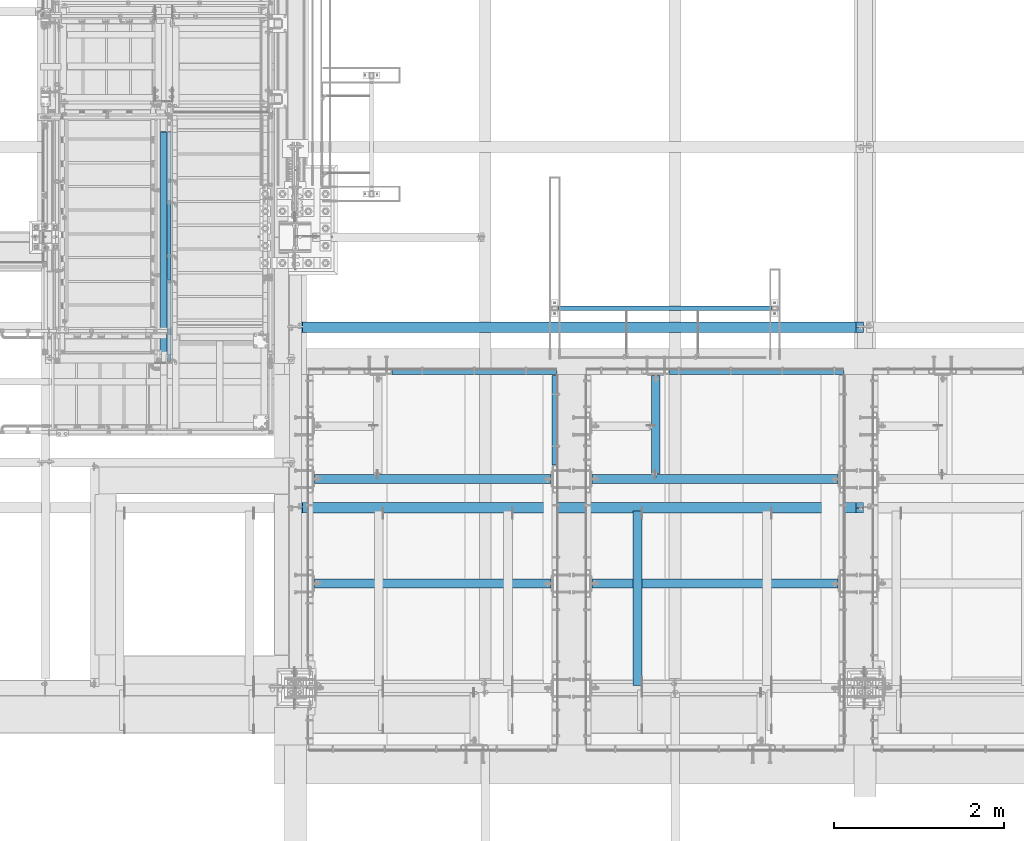
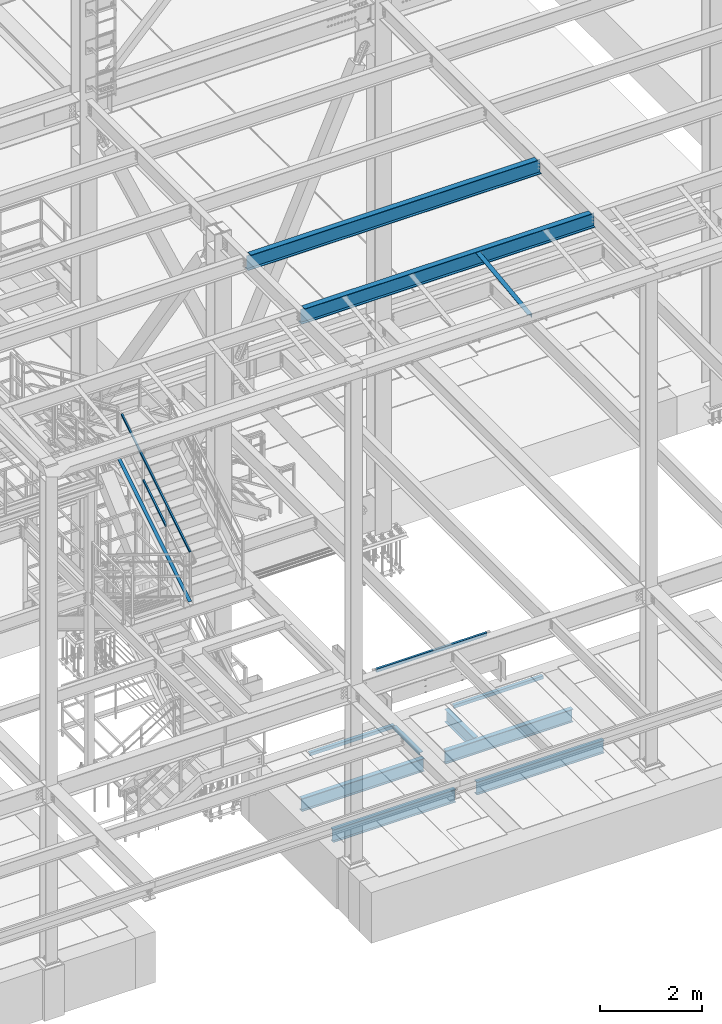
# One storey, part 1763 of 3843: 12 beams, 3 members, 14 elements without a shape of their own.
"""IFC2X3 building model written with IfcOpenShell, lengths in millimetres."""

from ifc_helpers import new_model, si_unit, frame, origin_with_axes, place, context, subcontext, project, spatial, faceted_brep, material, type_object, element, aggregate, save


model = new_model("IFC2X3")

# Units and contexts
model_context = context("Model", 3, precision=1e-05, world=origin_with_axes())
body_context = subcontext(model_context, "Body", "Model", "MODEL_VIEW")
ifc_project = project(units=[si_unit("LENGTHUNIT", "METRE", prefix="MILLI"), si_unit("AREAUNIT", "SQUARE_METRE"), si_unit("VOLUMEUNIT", "CUBIC_METRE"), si_unit("MASSUNIT", "GRAM", prefix="KILO"), si_unit("TIMEUNIT", "SECOND"), si_unit("PLANEANGLEUNIT", "RADIAN"), si_unit("SOLIDANGLEUNIT", "STERADIAN"), si_unit("THERMODYNAMICTEMPERATUREUNIT", "DEGREE_CELSIUS"), si_unit("LUMINOUSINTENSITYUNIT", "LUMEN")], contexts=[model_context])

# Site, building, storey
site_placement = place(None, origin_with_axes())
site = spatial("IfcSite", under=ifc_project, at=site_placement, CompositionType="ELEMENT")
building_placement = place(site_placement, origin_with_axes())
building = spatial("IfcBuilding", under=site, at=building_placement, Name="Undefined", CompositionType="ELEMENT")
storey_placement = place(building_placement, origin_with_axes())
storey = spatial("IfcBuildingStorey", under=building, at=storey_placement, Name="Undefined", CompositionType="ELEMENT", Elevation=0.0)

# Assembly, beam
assembly_1_placement = place(storey_placement, origin_with_axes())
assembly_1 = element("IfcElementAssembly", 1, at=assembly_1_placement, inside=storey, Name="FRAME", AssemblyPlace="NOTDEFINED", PredefinedType="RIGID_FRAME")
ifc_material_1 = material()
beam_type_1 = type_object("IfcBeamType", Name="HSS3X2X1/4", PredefinedType="NOTDEFINED")
beam_1_placement = place(assembly_1_placement, frame((58953.7793947567, 19468.65786883, 31267.4), z_axis=(0.0, 0.0, 1.0), x_axis=(1.0, 0.0, 0.0)))
beam_1 = element("IfcBeam", 2, at=beam_1_placement, type_object=beam_type_1, material=ifc_material_1, Name="FRAME", ObjectType="HSS3X2X1/4", context=body_context, shape_type="Brep", body=[
    faceted_brep([(67.8656249999985, 19.0499999999993, -31.75), (67.8656249999985, -19.0499999999993, -31.75), (2582.46562500002, -19.0499999999993, -31.75), (2582.46562500002, 19.0499999999993, -31.75), (67.8656249999985, -19.0499999999993, 31.75), (2582.46562500002, -19.0499999999993, 31.75), (67.8656249999985, 19.0499999999993, 31.75), (2582.46562500002, 19.0499999999993, 31.75), (67.8656249999985, 25.4000000000015, -38.0999999999985), (67.8656249999985, 25.4000000000015, 38.0999999999985), (2582.46562500002, 25.4000000000015, 38.0999999999985), (2582.46562500002, 25.4000000000015, -38.0999999999985), (67.8656249999985, -25.4000000000015, 38.0999999999985), (2582.46562500002, -25.4000000000015, 38.0999999999985), (67.8656249999985, -25.4000000000015, -38.0999999999985), (2582.46562500002, -25.4000000000015, -38.0999999999985)], [[[0, 1, 2, 3]], [[1, 4, 5, 2]], [[4, 6, 7, 5]], [[6, 0, 3, 7]], [[8, 9, 10, 11]], [[9, 12, 13, 10]], [[12, 14, 15, 13]], [[14, 8, 11, 15]], [[13, 15, 11, 10], [5, 7, 3, 2]], [[14, 12, 9, 8], [6, 4, 1, 0]]]),
])
aggregate(assembly_1, [beam_1])

# Assembly, members
assembly_2_placement = place(storey_placement, origin_with_axes())
assembly_2 = element("IfcElementAssembly", 3, at=assembly_2_placement, inside=storey, Name="RAIL", AssemblyPlace="NOTDEFINED", PredefinedType="RIGID_FRAME")
ifc_material_2 = material()
member_type_1 = type_object("IfcMemberType", Name="HSS1-1/2X1-1/2X1/4", PredefinedType="NOTDEFINED")
member_1_placement = place(assembly_2_placement, frame((54444.9000000038, 19786.6000000041, 36125.9581799186), z_axis=(0.0, -0.529536736899111, 0.848287005838379), x_axis=(0.0, 0.848287005838377, 0.529536736899114)))
member_1 = element("IfcMember", 4, at=member_1_placement, type_object=member_type_1, material=ifc_material_2, Name="RAIL", ObjectType="HSS1-1/2X1-1/2X1/4", context=body_context, shape_type="Brep", body=[
    faceted_brep([(34.3488397583606, -19.0499999999956, 19.0499992348923), (34.3488397583606, 19.0499992350015, 19.0499992348923), (10.5652043534537, 19.0499992350015, -19.0499992349432), (10.5652043534537, -19.0499992350015, -19.0499992349432), (30.3849004243275, -12.6999993300014, 12.6999993299178), (14.5291436874832, -12.6999993300014, -12.6999993299687), (14.5291436874832, 12.6999993300014, -12.6999993299687), (30.3849004243275, 12.6999993300014, 12.6999993299178), (1058.55956696786, 19.0499992350015, -19.0499992382502), (1058.55956696786, -19.0499992350015, -19.0499992382502), (1082.34320237271, -19.0499992350015, 19.0499992316145), (1082.34320237271, 19.0499992350015, 19.0499992316145), (1078.3792630387, -12.6999993299978, 12.6999993266436), (1078.3792630387, 12.6999993299978, 12.6999993266436), (1062.52350630188, 12.6999993299978, -12.6999993332684), (1062.52350630188, -12.6999993299978, -12.6999993332684)], [[[0, 1, 2, 3], [4, 5, 6, 7]], [[8, 9, 3, 2]], [[9, 10, 0, 3]], [[10, 11, 1, 0]], [[11, 8, 2, 1]], [[10, 9, 8, 11], [12, 13, 14, 15]], [[13, 12, 4, 7]], [[14, 13, 7, 6]], [[15, 14, 6, 5]], [[12, 15, 5, 4]]]),
])
member_2_placement = place(assembly_2_placement, frame((54444.8999999935, 21551.9000000515, 37761.3333313073), z_axis=(0.0, 0.529536736899111, -0.848287005838379), x_axis=(0.0, -0.848287005838377, -0.529536736899114)))
member_2 = element("IfcMember", 5, at=member_2_placement, type_object=member_type_1, material=ifc_material_2, Name="RAIL", ObjectType="HSS1-1/2X1-1/2X1/4", context=body_context, shape_type="Brep", body=[
    faceted_brep([(-3.63856705526268, 12.6999993300014, -12.6999993299469), (-3.63856705526268, -12.6999993300014, -12.6999993299469), (3180.96925284948, -12.6999993299978, -12.6999993398349), (3180.96925284948, 12.6999993299978, -12.6999993398349), (3.63856705247599, -12.6999993300014, 12.6999993299542), (3166.88231510687, -12.6999993299978, 12.6999993201716), (3.63856705247599, 12.6999993300014, 12.6999993299542), (3166.88231510687, 12.6999993299978, 12.6999993201716), (-5.45785065095697, 19.0499992350015, -19.0499992349214), (5.45785064817028, 19.0499992350015, 19.0499992349287), (3163.36058053812, 19.0499992350015, 19.0499992251644), (3184.49098741823, 19.0499992350015, -19.0499992448349), (5.45785064817028, -19.0499992350015, 19.0499992349287), (3163.36058053812, -19.0499992350015, 19.0499992251644), (-5.45785065095697, -19.0499992350015, -19.0499992349214), (3184.49098741823, -19.0499992350015, -19.0499992448349)], [[[0, 1, 2, 3]], [[1, 4, 5, 2]], [[4, 6, 7, 5]], [[6, 0, 3, 7]], [[8, 9, 10, 11]], [[9, 12, 13, 10]], [[12, 14, 15, 13]], [[14, 8, 11, 15]], [[13, 15, 11, 10], [5, 7, 3, 2]], [[14, 12, 9, 8], [6, 4, 1, 0]]]),
])
aggregate(assembly_2, [member_1, member_2])

# Assembly, beam
assembly_3_placement = place(storey_placement, origin_with_axes())
assembly_3 = element("IfcElementAssembly", 6, at=assembly_3_placement, inside=storey, Name="ANGLE", AssemblyPlace="NOTDEFINED", PredefinedType="RIGID_FRAME")
ifc_material_3 = material(Name="STEEL/A572-50")
beam_type_2 = type_object("IfcBeamType", Name="L4X4X3/8", PredefinedType="NOTDEFINED")
beam_2_placement = place(assembly_3_placement, frame((59958.2875, 17090.2662426835, 42392.9829998706), z_axis=(-1.0, 0.0, 0.0), x_axis=(0.0, -0.99246063250399, -0.122563832062241)))
beam_2 = element("IfcBeam", 7, at=beam_2_placement, type_object=beam_type_2, material=ifc_material_3, Name="ANGLE", ObjectType="L4X4X3/8", context=body_context, shape_type="Brep", body=[
    faceted_brep([(0.0, 50.8000000000029, -50.8000000000029), (0.0, 50.8000000000029, 50.8000000000029), (2072.3895061554, 50.8000000024476, 50.8000000000029), (2072.3895061554, 50.8000000024476, -50.8000000000029), (0.0, 41.2750000000015, 50.8000000000029), (2072.38950615541, 41.2750000024098, 50.8000000000029), (0.0, 41.2749999999942, -41.2750000000015), (2072.38950615541, 41.2750000024098, -41.2750000000015), (0.0, -50.8000000000029, -41.2750000000015), (2072.38950615556, -50.7999999979074, -41.2750000000015), (0.0, -50.8000000000029, -50.8000000000029), (2072.38950615556, -50.7999999979074, -50.8000000000029)], [[[0, 1, 2, 3]], [[1, 4, 5, 2]], [[4, 6, 7, 5]], [[6, 8, 9, 7]], [[8, 10, 11, 9]], [[10, 0, 3, 11]], [[5, 7, 9, 11, 3, 2]], [[10, 8, 6, 4, 1, 0]]]),
])
aggregate(assembly_3, [beam_2])

assembly_4_placement = place(storey_placement, origin_with_axes())
assembly_4 = element("IfcElementAssembly", 8, at=assembly_4_placement, inside=storey, Name="ANGLE", AssemblyPlace="NOTDEFINED", PredefinedType="RIGID_FRAME")
ifc_material_4 = material(Name="STEEL/A36")
beam_type_3 = type_object("IfcBeamType", Name="L3X3X1/4", PredefinedType="NOTDEFINED")
beam_3_placement = place(assembly_4_placement, frame((57067.4498493546, 18729.3250781256, 30391.1000030518), z_axis=(0.0, 0.0, -1.0), x_axis=(1.0, 0.0, 0.0)))
beam_3 = element("IfcBeam", 9, at=beam_3_placement, type_object=beam_type_3, material=ifc_material_4, Name="ANGLE", ObjectType="L3X3X1/4", context=body_context, shape_type="Brep", body=[
    faceted_brep([(0.0, 38.0999999999985, -38.0999999999985), (0.0, 38.0999999999985, 38.0999999999985), (1936.74991913254, 38.0999999999985, 38.0999999999985), (1936.74991913254, 38.0999999999985, -38.0999999999985), (0.0, 31.75, 38.0999999999985), (1936.74991913254, 31.75, 38.0999999999985), (0.0, 31.75, -31.75), (1936.74991913254, 31.75, -31.75), (0.0, -38.0999999999985, -31.75), (1936.74991913254, -38.0999999999985, -31.75), (0.0, -38.0999999999985, -38.0999999999985), (1936.74991913254, -38.0999999999985, -38.0999999999985)], [[[0, 1, 2, 3]], [[1, 4, 5, 2]], [[4, 6, 7, 5]], [[6, 8, 9, 7]], [[8, 10, 11, 9]], [[10, 0, 3, 11]], [[5, 7, 9, 11, 3, 2]], [[10, 8, 6, 4, 1, 0]]]),
])
aggregate(assembly_4, [beam_3])

assembly_5_placement = place(storey_placement, origin_with_axes())
assembly_5 = element("IfcElementAssembly", 10, at=assembly_5_placement, inside=storey, Name="ANGLE", AssemblyPlace="NOTDEFINED", PredefinedType="RIGID_FRAME")
beam_4_placement = place(assembly_5_placement, frame((60337.6998493548, 18729.3250110749, 30391.1000030518), z_axis=(0.0, 0.0, -1.0), x_axis=(1.0, 0.0, 0.0)))
beam_4 = element("IfcBeam", 11, at=beam_4_placement, type_object=beam_type_3, material=ifc_material_4, Name="ANGLE", ObjectType="L3X3X1/4", context=body_context, shape_type="Brep", body=[
    faceted_brep([(0.0, 38.0999999999985, -38.0999999999985), (0.0, 38.0999999999985, 38.0999999999985), (2044.69994004285, 38.0999999999985, 38.0999999999985), (2044.69994004285, 38.0999999999985, -38.0999999999985), (0.0, 31.75, 38.0999999999985), (2044.69994004285, 31.75, 38.0999999999985), (0.0, 31.75, -31.75), (2044.69994004285, 31.75, -31.75), (0.0, -38.0999999999985, -31.75), (2044.69994004285, -38.0999999999985, -31.75), (0.0, -38.0999999999985, -38.0999999999985), (2044.69994004285, -38.0999999999985, -38.0999999999985)], [[[0, 1, 2, 3]], [[1, 4, 5, 2]], [[4, 6, 7, 5]], [[6, 8, 9, 7]], [[8, 10, 11, 9]], [[10, 0, 3, 11]], [[5, 7, 9, 11, 3, 2]], [[10, 8, 6, 4, 1, 0]]]),
])
aggregate(assembly_5, [beam_4])

assembly_6_placement = place(storey_placement, origin_with_axes())
assembly_6 = element("IfcElementAssembly", 12, at=assembly_6_placement, inside=storey, Name="ANGLE", AssemblyPlace="NOTDEFINED", PredefinedType="RIGID_FRAME")
beam_5_placement = place(assembly_6_placement, frame((58991.4999969863, 18678.5250001143, 30391.1000045777), z_axis=(0.0, 0.0, -1.0), x_axis=(0.0, -1.0, 0.0)))
beam_5 = element("IfcBeam", 13, at=beam_5_placement, type_object=beam_type_3, material=ifc_material_4, Name="ANGLE", ObjectType="L3X3X1/4", context=body_context, shape_type="Brep", body=[
    faceted_brep([(0.0, 38.0999999999985, -38.0999999999985), (0.0, 38.0999999999985, 38.0999999999985), (1054.10000000005, 38.100000002436, 38.0999999999985), (1054.10000000005, 38.100000002436, -38.0999999999985), (0.0, 31.75, 38.0999999999985), (1054.10000000004, 31.7500000024302, 38.0999999999985), (0.0, 31.75, -31.75), (1054.10000000004, 31.7500000024302, -31.75), (0.0, -38.0999999999985, -31.75), (1054.09999999994, -38.0999999975611, -31.75), (0.0, -38.0999999999985, -38.0999999999985), (1054.09999999994, -38.0999999975611, -38.0999999999985)], [[[0, 1, 2, 3]], [[1, 4, 5, 2]], [[4, 6, 7, 5]], [[6, 8, 9, 7]], [[8, 10, 11, 9]], [[10, 0, 3, 11]], [[5, 7, 9, 11, 3, 2]], [[10, 8, 6, 4, 1, 0]]]),
])
aggregate(assembly_6, [beam_5])

# Assembly, member
assembly_7_placement = place(storey_placement, origin_with_axes())
assembly_7 = element("IfcElementAssembly", 14, at=assembly_7_placement, inside=storey, Name="ref.", AssemblyPlace="NOTDEFINED", PredefinedType="RIGID_FRAME")
ifc_material_5 = material(Name="STEEL/Steel_Undefined")
member_type_2 = type_object("IfcMemberType", PredefinedType="NOTDEFINED")
member_3_placement = place(assembly_7_placement, frame((54381.4, 18753.2312791328, 34973.6854436256), z_axis=(-1.0, 0.0, 0.0), x_axis=(0.0, 0.848287005838377, 0.529536736899114)))
member_3 = element("IfcMember", 15, at=member_3_placement, type_object=member_type_2, material=ifc_material_5, Name="ref.", context=body_context, shape_type="Brep", body=[
    faceted_brep([(0.0, 3.17500000000291, -38.0999999999985), (0.0, 3.17500000000291, 38.0999999999985), (3292.60361921031, 3.17500001020016, 38.0999999999985), (3292.60361921031, 3.17500001020016, -38.0999999999985), (0.0, -3.17500000000291, 38.0999999999985), (3292.60361921029, -3.1749999897911, 38.0999999999985), (0.0, -3.17500000000291, -38.0999999999985), (3292.60361921029, -3.1749999897911, -38.0999999999985)], [[[0, 1, 2, 3]], [[1, 4, 5, 2]], [[4, 6, 7, 5]], [[6, 0, 3, 7]], [[5, 7, 3, 2]], [[6, 4, 1, 0]]]),
])
aggregate(assembly_7, [member_3])

# Assembly, beam
assembly_8_placement = place(storey_placement, origin_with_axes())
assembly_8 = element("IfcElementAssembly", 16, at=assembly_8_placement, inside=storey, Name="BEAM", AssemblyPlace="NOTDEFINED", PredefinedType="RIGID_FRAME")
ifc_material_6 = material(Name="STEEL/A992")
beam_type_4 = type_object("IfcBeamType", Name="W14X26", PredefinedType="NOTDEFINED")
beam_6_placement = place(assembly_8_placement, frame((55930.8, 19245.58, 42292.5875), z_axis=(0.0, 0.0, 1.0), x_axis=(1.0, 0.0, 0.0)))
beam_6 = element("IfcBeam", 17, at=beam_6_placement, type_object=beam_type_4, material=ifc_material_6, Name="BEAM", ObjectType="W14X26", context=body_context, shape_type="Brep", body=[
    faceted_brep([(6602.41249847413, -63.5, 176.212500000001), (6602.41249847413, -63.5, 165.099999999999), (6602.41249847413, -3.17499999999927, 165.099999999999), (6602.41249847413, -3.17499999999927, 153.987499809264), (6602.41249847413, 3.17499999999927, 153.987499809264), (6602.41249847413, 3.17499999999927, 165.099999999999), (6602.41249847413, 63.5, 165.099999999999), (6602.41249847413, 63.5, 176.212500000001), (6603.37922839671, -3.17499999999927, 149.127420291217), (6603.37922839671, 3.17499999999927, 149.127420291217), (6606.13224229719, -3.17499999999927, 145.007243823064), (6606.13224229719, 3.17499999999927, 145.007243823064), (6610.25241876535, -3.17499999999927, 142.25422992259), (6610.25241876535, 3.17499999999927, 142.25422992259), (6615.11249828339, -3.17499999999927, 141.287499999999), (6615.11249828339, 3.17499999999927, 141.287499999999), (6687.34375, -3.17499999999927, 141.287499999999), (6687.34375, 3.17499999999927, 141.287499999999), (82.5500030517651, -63.5, 176.212500000001), (82.5500030517651, 63.5, 176.212500000001), (82.5500030517651, 63.5, 165.099999999999), (82.5500030517651, 3.17499999999927, 165.099999999999), (82.5500030517651, 3.17499999999927, 160.33749980927), (82.5500030517651, -3.17499999999927, 160.33749980927), (82.5500030517651, -3.17499999999927, 165.099999999999), (82.5500030517651, -63.5, 165.099999999999), (81.5832731291739, 3.17499999999927, 155.477420291223), (81.5832731291739, -3.17499999999927, 155.477420291223), (78.8302592287, 3.17499999999927, 151.357243823069), (78.8302592287, -3.17499999999927, 151.357243823069), (74.7100827605464, 3.17499999999927, 148.604229922596), (74.7100827605464, -3.17499999999927, 148.604229922596), (69.8500032425, 3.17499999999927, 147.637500000004), (69.8500032425, -3.17499999999927, 147.637500000004), (15.875, 3.17499999999927, 147.637500000004), (15.875, -3.17499999999927, 147.637500000004), (15.875, 3.17499999999927, 125.412499999999), (15.875, 3.17499999999927, -105.1875), (15.875, 3.17499999999927, -165.099999999999), (15.875, 63.5, -165.099999999999), (15.875, 63.5, -176.212500000001), (15.875, -63.5, -176.212500000001), (15.875, -63.5, -165.099999999999), (15.875, -3.17499999999927, -165.099999999999), (6687.34375, 3.17499999999927, -165.099999999999), (6687.34375, 63.5, -165.099999999999), (6687.34375, 63.5, -176.212500000001), (6687.34375, -63.5, -176.212500000001), (6687.34375, -63.5, -165.099999999999), (6687.34375, -3.17499999999927, -165.099999999999), (6687.34375, 3.17499999999927, 125.412499999999), (6687.34375, 3.17499999999927, -105.187499999993)], [[[0, 1, 2, 3, 4, 5, 6, 7]], [[8, 9, 4, 3]], [[10, 11, 9, 8]], [[12, 13, 11, 10]], [[14, 15, 13, 12]], [[16, 17, 15, 14]], [[18, 19, 20, 21, 22, 23, 24, 25]], [[23, 22, 26, 27]], [[27, 26, 28, 29]], [[29, 28, 30, 31]], [[31, 30, 32, 33]], [[33, 32, 34, 35]], [[36, 37, 38, 39, 40, 41, 42, 43, 35, 34]], [[39, 38, 44, 45]], [[40, 39, 45, 46]], [[41, 40, 46, 47]], [[42, 41, 47, 48]], [[43, 42, 48, 49]], [[12, 10, 8, 3, 2, 24, 23, 27, 29, 31, 33, 35, 43, 49, 16, 14]], [[25, 24, 2, 1]], [[18, 25, 1, 0]], [[19, 18, 0, 7]], [[20, 19, 7, 6]], [[21, 20, 6, 5]], [[50, 51, 44, 38, 37, 36, 34, 32, 30, 28, 26, 22, 21, 5, 4, 9, 11, 13, 15, 17]], [[49, 48, 47, 46, 45, 44, 51, 50, 17, 16]]]),
])
aggregate(assembly_8, [beam_6])

assembly_9_placement = place(storey_placement, origin_with_axes())
assembly_9 = element("IfcElementAssembly", 18, at=assembly_9_placement, inside=storey, Name="BEAM", AssemblyPlace="NOTDEFINED", PredefinedType="RIGID_FRAME")
beam_7_placement = place(assembly_9_placement, frame((55930.8, 17122.14, 42292.5875), z_axis=(0.0, 0.0, 1.0), x_axis=(1.0, 0.0, 0.0)))
beam_7 = element("IfcBeam", 19, at=beam_7_placement, type_object=beam_type_4, material=ifc_material_6, Name="BEAM", ObjectType="W14X26", context=body_context, shape_type="Brep", body=[
    faceted_brep([(6602.41249847413, -63.5, 176.212500000001), (6602.41249847413, -63.5, 165.099999999999), (6602.41249847413, -3.17499999999927, 165.099999999999), (6602.41249847413, -3.17499999999927, 153.987499809264), (6602.41249847413, 3.17499999999927, 153.987499809264), (6602.41249847413, 3.17499999999927, 165.099999999999), (6602.41249847413, 63.5, 165.099999999999), (6602.41249847413, 63.5, 176.212500000001), (6603.37922839671, -3.17499999999927, 149.127420291217), (6603.37922839671, 3.17499999999927, 149.127420291217), (6606.13224229719, -3.17499999999927, 145.007243823064), (6606.13224229719, 3.17499999999927, 145.007243823064), (6610.25241876535, -3.17499999999927, 142.25422992259), (6610.25241876535, 3.17499999999927, 142.25422992259), (6615.11249828339, -3.17499999999927, 141.287499999999), (6615.11249828339, 3.17499999999927, 141.287499999999), (6687.34375, -3.17499999999927, 141.287499999999), (6687.34375, 3.17499999999927, 141.287499999999), (82.5500030517651, -63.5, 176.212500000001), (82.5500030517651, 63.5, 176.212500000001), (82.5500030517651, 63.5, 165.099999999999), (82.5500030517651, 3.17499999999927, 165.099999999999), (82.5500030517651, 3.17499999999927, 160.33749980927), (82.5500030517651, -3.17499999999927, 160.33749980927), (82.5500030517651, -3.17499999999927, 165.099999999999), (82.5500030517651, -63.5, 165.099999999999), (81.5832731291739, 3.17499999999927, 155.477420291223), (81.5832731291739, -3.17499999999927, 155.477420291223), (78.8302592287, 3.17499999999927, 151.357243823069), (78.8302592287, -3.17499999999927, 151.357243823069), (74.7100827605464, 3.17499999999927, 148.604229922596), (74.7100827605464, -3.17499999999927, 148.604229922596), (69.8500032425, 3.17499999999927, 147.637500000004), (69.8500032425, -3.17499999999927, 147.637500000004), (15.875, 3.17499999999927, 147.637500000004), (15.875, -3.17499999999927, 147.637500000004), (15.875, 3.17499999999927, 125.412499999999), (15.875, 3.17499999999927, -105.1875), (15.875, 3.17499999999927, -165.099999999999), (15.875, 63.5, -165.099999999999), (15.875, 63.5, -176.212500000001), (15.875, -63.5, -176.212500000001), (15.875, -63.5, -165.099999999999), (15.875, -3.17499999999927, -165.099999999999), (6687.34375, 3.17499999999927, -165.099999999999), (6687.34375, 63.5, -165.099999999999), (6687.34375, 63.5, -176.212500000001), (6687.34375, -63.5, -176.212500000001), (6687.34375, -63.5, -165.099999999999), (6687.34375, -3.17499999999927, -165.099999999999), (6687.34375, 3.17499999999927, 125.412499999999), (6687.34375, 3.17499999999927, -105.187499999993)], [[[0, 1, 2, 3, 4, 5, 6, 7]], [[8, 9, 4, 3]], [[10, 11, 9, 8]], [[12, 13, 11, 10]], [[14, 15, 13, 12]], [[16, 17, 15, 14]], [[18, 19, 20, 21, 22, 23, 24, 25]], [[23, 22, 26, 27]], [[27, 26, 28, 29]], [[29, 28, 30, 31]], [[31, 30, 32, 33]], [[33, 32, 34, 35]], [[36, 37, 38, 39, 40, 41, 42, 43, 35, 34]], [[39, 38, 44, 45]], [[40, 39, 45, 46]], [[41, 40, 46, 47]], [[42, 41, 47, 48]], [[43, 42, 48, 49]], [[12, 10, 8, 3, 2, 24, 23, 27, 29, 31, 33, 35, 43, 49, 16, 14]], [[25, 24, 2, 1]], [[18, 25, 1, 0]], [[19, 18, 0, 7]], [[20, 19, 7, 6]], [[21, 20, 6, 5]], [[50, 51, 44, 38, 37, 36, 34, 32, 30, 28, 26, 22, 21, 5, 4, 9, 11, 13, 15, 17]], [[49, 48, 47, 46, 45, 44, 51, 50, 17, 16]]]),
])
aggregate(assembly_9, [beam_7])

assembly_10_placement = place(storey_placement, origin_with_axes())
assembly_10 = element("IfcElementAssembly", 20, at=assembly_10_placement, inside=storey, Name="BEAM", AssemblyPlace="NOTDEFINED", PredefinedType="RIGID_FRAME")
beam_type_5 = type_object("IfcBeamType", Name="W12X16", PredefinedType="NOTDEFINED")
beam_8_placement = place(assembly_10_placement, frame((60172.6, 17459.325, 30276.8), z_axis=(0.0, 0.0, 1.0), x_axis=(0.0, 1.0, 0.0)))
beam_8 = element("IfcBeam", 21, at=beam_8_placement, type_object=beam_type_5, material=ifc_material_6, Name="BEAM", ObjectType="W12X16", context=body_context, shape_type="Brep", body=[
    faceted_brep([(15.875, -3.17500000000291, -127.0), (15.875, 3.17500000000291, -127.0), (53.9750001907341, 3.17500000000291, -127.0), (53.9750001907341, -3.17500000000291, -127.0), (58.8350797087805, 3.17500000000291, -127.966729922588), (58.8350797087805, -3.17500000000291, -127.966729922588), (62.9552561769342, 3.17500000000291, -130.719743823065), (62.9552561769342, -3.17500000000291, -130.719743823065), (65.7082700774117, 3.17500000000291, -134.839920291219), (65.7082700774117, -3.17500000000291, -134.839920291219), (66.6749999999993, -3.17500000000291, -139.699999809265), (66.6749999999993, 3.17500000000291, -139.699999809265), (66.6749999999993, 3.17500000000291, -146.049999999999), (66.6749999999993, 50.8000000000029, -146.049999999999), (66.6749999999993, 50.8000000000029, -152.400000000001), (66.6749999999993, -50.8000000000029, -152.400000000001), (66.6749999999993, -50.8000000000029, -146.049999999999), (66.6749999999993, -3.17500000000291, -146.049999999999), (1219.19999694822, -50.8000000000029, 146.049999999999), (1219.19999694822, -50.8000000000029, 152.400000000001), (66.6749999999993, -50.8000000000029, 152.400000000001), (66.6749999999993, -50.8000000000029, 146.049999999999), (1219.19999694822, 50.8000000000029, 152.400000000001), (66.6749999999993, 50.8000000000029, 152.400000000001), (1219.19999694822, 50.8000000000029, 146.049999999999), (66.6749999999993, 50.8000000000029, 146.049999999999), (1219.19999694822, 3.17500000000291, 146.049999999999), (66.6749999999993, 3.17500000000291, 146.049999999999), (53.9750001907341, -3.17500000000291, 127.0), (53.9750001907341, 3.17500000000291, 127.0), (15.875, 3.17500000000291, 127.0), (15.875, -3.17500000000291, 127.0), (58.8350797087805, -3.17500000000291, 127.966729922588), (58.8350797087805, 3.17500000000291, 127.966729922588), (62.9552561769342, -3.17500000000291, 130.719743823065), (62.9552561769342, 3.17500000000291, 130.719743823065), (65.7082700774117, -3.17500000000291, 134.839920291219), (65.7082700774117, 3.17500000000291, 134.839920291219), (66.6749999999993, -3.17500000000291, 139.699999809265), (66.6749999999993, 3.17500000000291, 139.699999809265), (66.6749999999993, -3.17500000000291, 146.049999999999), (1219.19999694822, -3.17500000000291, 146.049999999999), (1219.19999694822, 3.17500000000291, -146.049999999999), (1219.19999694822, -3.17500000000291, -146.049999999999), (1219.19999694822, -50.8000000000029, -146.049999999999), (1219.19999694822, -50.8000000000029, -152.400000000001), (1219.19999694822, 50.8000000000029, -152.400000000001), (1219.19999694822, 50.8000000000029, -146.049999999999), (15.875, 3.17500000000291, -116.299999999999), (15.875, 3.17500000000291, 114.299999999999)], [[[0, 1, 2, 3]], [[3, 2, 4, 5]], [[5, 4, 6, 7]], [[7, 6, 8, 9]], [[10, 11, 12, 13, 14, 15, 16, 17]], [[9, 8, 11, 10]], [[18, 19, 20, 21]], [[19, 22, 23, 20]], [[22, 24, 25, 23]], [[24, 26, 27, 25]], [[28, 29, 30, 31]], [[32, 33, 29, 28]], [[34, 35, 33, 32]], [[36, 37, 35, 34]], [[38, 39, 37, 36]], [[20, 23, 25, 27, 39, 38, 40, 21]], [[41, 18, 21, 40]], [[42, 26, 24, 22, 19, 18, 41, 43, 44, 45, 46, 47]], [[44, 43, 17, 16]], [[45, 44, 16, 15]], [[46, 45, 15, 14]], [[47, 46, 14, 13]], [[42, 47, 13, 12]], [[6, 4, 2, 1, 48, 49, 30, 29, 33, 35, 37, 39, 27, 26, 42, 12, 11, 8]], [[31, 30, 49, 48, 1, 0]], [[43, 41, 40, 38, 36, 34, 32, 28, 31, 0, 3, 5, 7, 9, 10, 17]]]),
])
aggregate(assembly_10, [beam_8])

assembly_11_placement = place(storey_placement, origin_with_axes())
assembly_11 = element("IfcElementAssembly", 22, at=assembly_11_placement, inside=storey, Name="BEAM", AssemblyPlace="NOTDEFINED", PredefinedType="RIGID_FRAME")
beam_type_6 = type_object("IfcBeamType", Name="W12X22", PredefinedType="NOTDEFINED")
beam_9_placement = place(assembly_11_placement, frame((59410.6, 17459.325, 30273.625), z_axis=(0.0, 0.0, 1.0), x_axis=(1.0, 0.0, 0.0)))
beam_9 = element("IfcBeam", 23, at=beam_9_placement, type_object=beam_type_6, material=ifc_material_6, Name="BEAM", ObjectType="W12X22", context=body_context, shape_type="Brep", body=[
    faceted_brep([(12.7000030517593, 50.7999999999993, -155.575000000001), (12.7000030517593, 50.7999999999993, -144.462500000001), (2908.29999694825, 50.7999999999993, -144.462500000001), (2908.29999694825, 50.7999999999993, -155.575000000001), (12.7000030517593, 3.17499999999927, -144.462500000001), (2908.29999694825, 3.17499999999927, -144.462500000001), (12.7000030517593, 3.17499999999927, 144.462500000001), (2908.29999694825, 3.17499999999927, 144.462500000001), (12.7000030517593, 50.7999999999993, 144.462500000001), (2908.29999694825, 50.7999999999993, 144.462500000001), (12.7000030517593, 50.7999999999993, 155.575000000001), (2908.29999694825, 50.7999999999993, 155.575000000001), (12.7000030517593, -50.7999999999993, 155.575000000001), (2908.29999694825, -50.7999999999993, 155.575000000001), (12.7000030517593, -50.7999999999993, 144.462500000001), (2908.29999694825, -50.7999999999993, 144.462500000001), (12.7000030517593, -3.17499999999927, 144.462500000001), (2908.29999694825, -3.17499999999927, 144.462500000001), (12.7000030517593, -3.17499999999927, -144.462500000001), (2908.29999694825, -3.17499999999927, -144.462500000001), (12.7000030517593, -50.7999999999993, -144.462500000001), (2908.29999694825, -50.7999999999993, -144.462500000001), (12.7000030517593, -50.7999999999993, -155.575000000001), (2908.29999694825, -50.7999999999993, -155.575000000001)], [[[0, 1, 2, 3]], [[1, 4, 5, 2]], [[4, 6, 7, 5]], [[6, 8, 9, 7]], [[8, 10, 11, 9]], [[10, 12, 13, 11]], [[12, 14, 15, 13]], [[14, 16, 17, 15]], [[16, 18, 19, 17]], [[18, 20, 21, 19]], [[20, 22, 23, 21]], [[22, 0, 3, 23]], [[5, 7, 9, 11, 13, 15, 17, 19, 21, 23, 3, 2]], [[22, 20, 18, 16, 14, 12, 10, 8, 6, 4, 1, 0]]]),
])
aggregate(assembly_11, [beam_9])

assembly_12_placement = place(storey_placement, origin_with_axes())
assembly_12 = element("IfcElementAssembly", 24, at=assembly_12_placement, inside=storey, Name="BEAM", AssemblyPlace="NOTDEFINED", PredefinedType="RIGID_FRAME")
beam_10_placement = place(assembly_12_placement, frame((56140.35, 17459.325, 30273.625), z_axis=(0.0, 0.0, 1.0), x_axis=(1.0, 0.0, 0.0)))
beam_10 = element("IfcBeam", 25, at=beam_10_placement, type_object=beam_type_6, material=ifc_material_6, Name="BEAM", ObjectType="W12X22", context=body_context, shape_type="Brep", body=[
    faceted_brep([(12.7000030517593, 50.7999999999993, -155.575000000001), (12.7000030517593, 50.7999999999993, -144.462500000001), (2800.34999694824, 50.7999999999993, -144.462500000001), (2800.34999694824, 50.7999999999993, -155.575000000001), (12.7000030517593, 3.17499999999927, -144.462500000001), (2800.34999694824, 3.17499999999927, -144.462500000001), (12.7000030517593, 3.17499999999927, 144.462500000001), (2800.34999694824, 3.17499999999927, 144.462500000001), (12.7000030517593, 50.7999999999993, 144.462500000001), (2800.34999694824, 50.7999999999993, 144.462500000001), (12.7000030517593, 50.7999999999993, 155.575000000001), (2800.34999694824, 50.7999999999993, 155.575000000001), (12.7000030517593, -50.7999999999993, 155.575000000001), (2800.34999694824, -50.7999999999993, 155.575000000001), (12.7000030517593, -50.7999999999993, 144.462500000001), (2800.34999694824, -50.7999999999993, 144.462500000001), (12.7000030517593, -3.17499999999927, 144.462500000001), (2800.34999694824, -3.17499999999927, 144.462500000001), (12.7000030517593, -3.17499999999927, -144.462500000001), (2800.34999694824, -3.17499999999927, -144.462500000001), (12.7000030517593, -50.7999999999993, -144.462500000001), (2800.34999694824, -50.7999999999993, -144.462500000001), (12.7000030517593, -50.7999999999993, -155.575000000001), (2800.34999694824, -50.7999999999993, -155.575000000001)], [[[0, 1, 2, 3]], [[1, 4, 5, 2]], [[4, 6, 7, 5]], [[6, 8, 9, 7]], [[8, 10, 11, 9]], [[10, 12, 13, 11]], [[12, 14, 15, 13]], [[14, 16, 17, 15]], [[16, 18, 19, 17]], [[18, 20, 21, 19]], [[20, 22, 23, 21]], [[22, 0, 3, 23]], [[5, 7, 9, 11, 13, 15, 17, 19, 21, 23, 3, 2]], [[22, 20, 18, 16, 14, 12, 10, 8, 6, 4, 1, 0]]]),
])
aggregate(assembly_12, [beam_10])

assembly_13_placement = place(storey_placement, origin_with_axes())
assembly_13 = element("IfcElementAssembly", 26, at=assembly_13_placement, inside=storey, Name="BEAM", AssemblyPlace="NOTDEFINED", PredefinedType="RIGID_FRAME")
beam_11_placement = place(assembly_13_placement, frame((59410.6, 16229.0125, 30273.625), z_axis=(0.0, 0.0, 1.0), x_axis=(1.0, 0.0, 0.0)))
beam_11 = element("IfcBeam", 27, at=beam_11_placement, type_object=beam_type_6, material=ifc_material_6, Name="BEAM", ObjectType="W12X22", context=body_context, shape_type="Brep", body=[
    faceted_brep([(12.7000030517593, 50.7999999999993, -155.575000000001), (12.7000030517593, 50.7999999999993, -144.462500000001), (2908.29999694825, 50.7999999999993, -144.462500000001), (2908.29999694825, 50.7999999999993, -155.575000000001), (12.7000030517593, 3.17499999999927, -144.462500000001), (2908.29999694825, 3.17499999999927, -144.462500000001), (12.7000030517593, 3.17499999999927, 144.462500000001), (2908.29999694825, 3.17499999999927, 144.462500000001), (12.7000030517593, 50.7999999999993, 144.462500000001), (2908.29999694825, 50.7999999999993, 144.462500000001), (12.7000030517593, 50.7999999999993, 155.575000000001), (2908.29999694825, 50.7999999999993, 155.575000000001), (12.7000030517593, -50.7999999999993, 155.575000000001), (2908.29999694825, -50.7999999999993, 155.575000000001), (12.7000030517593, -50.7999999999993, 144.462500000001), (2908.29999694825, -50.7999999999993, 144.462500000001), (12.7000030517593, -3.17499999999927, 144.462500000001), (2908.29999694825, -3.17499999999927, 144.462500000001), (12.7000030517593, -3.17499999999927, -144.462500000001), (2908.29999694825, -3.17499999999927, -144.462500000001), (12.7000030517593, -50.7999999999993, -144.462500000001), (2908.29999694825, -50.7999999999993, -144.462500000001), (12.7000030517593, -50.7999999999993, -155.575000000001), (2908.29999694825, -50.7999999999993, -155.575000000001)], [[[0, 1, 2, 3]], [[1, 4, 5, 2]], [[4, 6, 7, 5]], [[6, 8, 9, 7]], [[8, 10, 11, 9]], [[10, 12, 13, 11]], [[12, 14, 15, 13]], [[14, 16, 17, 15]], [[16, 18, 19, 17]], [[18, 20, 21, 19]], [[20, 22, 23, 21]], [[22, 0, 3, 23]], [[5, 7, 9, 11, 13, 15, 17, 19, 21, 23, 3, 2]], [[22, 20, 18, 16, 14, 12, 10, 8, 6, 4, 1, 0]]]),
])
aggregate(assembly_13, [beam_11])

assembly_14_placement = place(storey_placement, origin_with_axes())
assembly_14 = element("IfcElementAssembly", 28, at=assembly_14_placement, inside=storey, Name="BEAM", AssemblyPlace="NOTDEFINED", PredefinedType="RIGID_FRAME")
beam_12_placement = place(assembly_14_placement, frame((56140.35, 16229.0125, 30273.625), z_axis=(0.0, 0.0, 1.0), x_axis=(1.0, 0.0, 0.0)))
beam_12 = element("IfcBeam", 29, at=beam_12_placement, type_object=beam_type_6, material=ifc_material_6, Name="BEAM", ObjectType="W12X22", context=body_context, shape_type="Brep", body=[
    faceted_brep([(12.7000030517593, 50.7999999999993, -155.575000000001), (12.7000030517593, 50.7999999999993, -144.462500000001), (2800.34999694824, 50.7999999999993, -144.462500000001), (2800.34999694824, 50.7999999999993, -155.575000000001), (12.7000030517593, 3.17499999999927, -144.462500000001), (2800.34999694824, 3.17499999999927, -144.462500000001), (12.7000030517593, 3.17499999999927, 144.462500000001), (2800.34999694824, 3.17499999999927, 144.462500000001), (12.7000030517593, 50.7999999999993, 144.462500000001), (2800.34999694824, 50.7999999999993, 144.462500000001), (12.7000030517593, 50.7999999999993, 155.575000000001), (2800.34999694824, 50.7999999999993, 155.575000000001), (12.7000030517593, -50.7999999999993, 155.575000000001), (2800.34999694824, -50.7999999999993, 155.575000000001), (12.7000030517593, -50.7999999999993, 144.462500000001), (2800.34999694824, -50.7999999999993, 144.462500000001), (12.7000030517593, -3.17499999999927, 144.462500000001), (2800.34999694824, -3.17499999999927, 144.462500000001), (12.7000030517593, -3.17499999999927, -144.462500000001), (2800.34999694824, -3.17499999999927, -144.462500000001), (12.7000030517593, -50.7999999999993, -144.462500000001), (2800.34999694824, -50.7999999999993, -144.462500000001), (12.7000030517593, -50.7999999999993, -155.575000000001), (2800.34999694824, -50.7999999999993, -155.575000000001)], [[[0, 1, 2, 3]], [[1, 4, 5, 2]], [[4, 6, 7, 5]], [[6, 8, 9, 7]], [[8, 10, 11, 9]], [[10, 12, 13, 11]], [[12, 14, 15, 13]], [[14, 16, 17, 15]], [[16, 18, 19, 17]], [[18, 20, 21, 19]], [[20, 22, 23, 21]], [[22, 0, 3, 23]], [[5, 7, 9, 11, 13, 15, 17, 19, 21, 23, 3, 2]], [[22, 20, 18, 16, 14, 12, 10, 8, 6, 4, 1, 0]]]),
])
aggregate(assembly_14, [beam_12])

save(model, "model.ifc")
